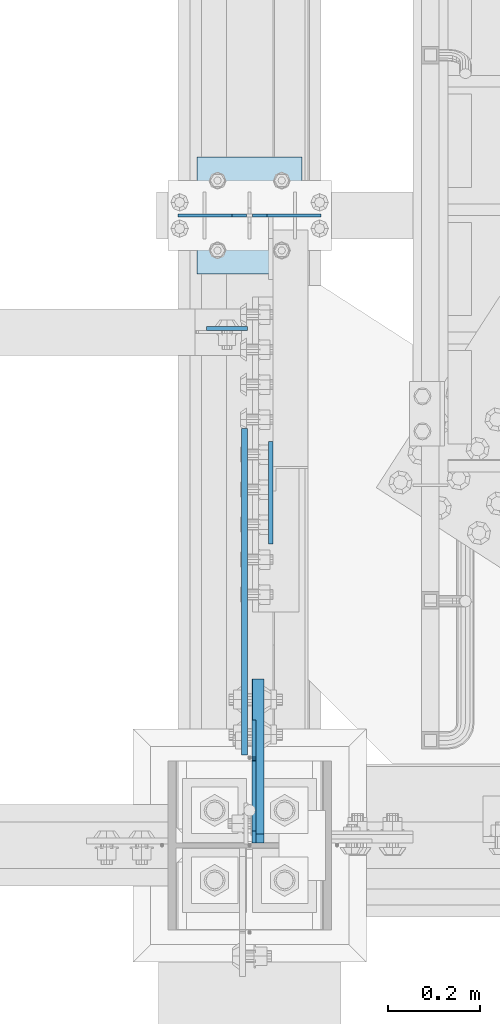
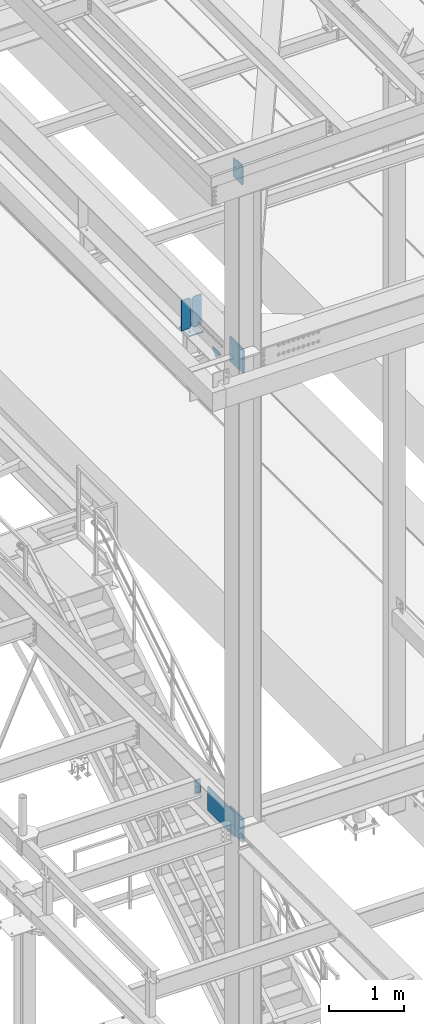
# One storey, part 3020 of 3843: 9 plates, 4 elements without a shape of their own.
"""IFC2X3 building model written with IfcOpenShell, lengths in millimetres."""

import ifcopenshell
import ifcopenshell.guid

model = None  # the IFC model being written
_history = None  # IfcOwnerHistory: only IFC2X3 demands one
_inside = {}  # id of a spatial element -> (the spatial element, [elements in it])
_under = {}  # id of a project, library or spatial element -> (it, [spatial elements below it])
_declared = {}  # id of a project -> (the project, [libraries it declares])
_typed = {}  # id of a type object -> (the type object, [elements of that type])
_made_of = {}  # id of a material, layer set ... -> (it, [elements and type objects made of it])


def new_model(schema):
    """Start an empty IFC model of exactly this schema.

    Asked for "IFC4X3", IfcOpenShell would pick the latest addendum, in which some entities
    have other attributes; the version numbers below select the first issue.
    IFC2X3 requires an IfcOwnerHistory on every rooted entity: one is made here for all.
    """
    global model, _history
    if schema == "IFC4X3":
        model = ifcopenshell.file(schema_version=(4, 3, 0, 0))
    else:
        model = ifcopenshell.file(schema=schema)
    _inside.clear()
    _under.clear()
    _declared.clear()
    _typed.clear()
    _made_of.clear()
    _history = None
    if model.schema == "IFC2X3":
        org = make("IfcOrganization", Name="unknown")
        user = make(
            "IfcPersonAndOrganization",
            ThePerson=make("IfcPerson", FamilyName="unknown"),
            TheOrganization=org,
        )
        app = make(
            "IfcApplication",
            ApplicationDeveloper=org,
            Version="unknown",
            ApplicationFullName="unknown",
            ApplicationIdentifier="unknown",
        )
        _history = make(
            "IfcOwnerHistory",
            OwningUser=user,
            OwningApplication=app,
            ChangeAction="ADDED",
            CreationDate=0,
        )
    return model


def make(cls, **values):
    """One entity of the class cls with the attributes given. An attribute that is None is left unset."""
    return model.create_entity(
        cls, **{name: value for name, value in values.items() if value is not None}
    )


def rooted(cls, **values):
    """An entity with a GlobalId (a new one), such as an element, a storey or a relation."""
    return make(cls, GlobalId=ifcopenshell.guid.new(), OwnerHistory=_history, **values)


def si_unit(unit_type, name, prefix=None):
    """IfcSIUnit, for example si_unit("LENGTHUNIT", "METRE", prefix="MILLI")."""
    return make("IfcSIUnit", UnitType=unit_type, Prefix=prefix, Name=name)


def assignment(units):
    """IfcUnitAssignment: the units of a project."""
    return None if units is None else make("IfcUnitAssignment", Units=units)


def point(xyz):
    """IfcCartesianPoint."""
    return None if xyz is None else make("IfcCartesianPoint", Coordinates=xyz)


def direction(xyz):
    """IfcDirection."""
    return None if xyz is None else make("IfcDirection", DirectionRatios=xyz)


def frame(location, z_axis=None, x_axis=None):
    """IfcAxis2Placement3D, a coordinate frame: its origin and axes. An axis left out is left unset."""
    return make(
        "IfcAxis2Placement3D",
        Location=point(location),
        Axis=direction(z_axis),
        RefDirection=direction(x_axis),
    )


def origin_with_axes():
    """The frame at (0, 0, 0) with the z axis (0, 0, 1) and the x axis (1, 0, 0) written out."""
    return frame((0.0, 0.0, 0.0), z_axis=(0.0, 0.0, 1.0), x_axis=(1.0, 0.0, 0.0))


def place(relative_to, where):
    """IfcLocalPlacement: puts the frame where relative to a parent placement (None: the world)."""
    return make(
        "IfcLocalPlacement", PlacementRelTo=relative_to, RelativePlacement=where
    )


def context(
    kind, dimensions, precision=None, world=None, true_north=None, identifier=None
):
    """IfcGeometricRepresentationContext, for example the 3D "Model" context."""
    return make(
        "IfcGeometricRepresentationContext",
        ContextIdentifier=identifier,
        ContextType=kind,
        CoordinateSpaceDimension=dimensions,
        Precision=precision,
        WorldCoordinateSystem=world,
        TrueNorth=true_north,
    )


def subcontext(parent, identifier, kind, view, scale=None):
    """IfcGeometricRepresentationSubContext, for example "Body" below "Model"."""
    return make(
        "IfcGeometricRepresentationSubContext",
        ContextIdentifier=identifier,
        ContextType=kind,
        ParentContext=parent,
        TargetScale=scale,
        TargetView=view,
    )


def project(units=None, contexts=None):
    """IfcProject with its units and contexts."""
    return rooted(
        "IfcProject",
        Name="project",
        RepresentationContexts=contexts,
        UnitsInContext=assignment(units),
    )


def spatial(cls, under=None, at=None, **own):
    """A site, building, storey or space (cls), placed at a placement, below another one or the project."""
    s = rooted(cls, ObjectPlacement=at, **own)
    if under is not None:
        _under.setdefault(under.id(), (under, []))[1].append(s)
    return s


def faces_of(points, faces, orient=None, outer=None):
    """IfcFace entities. A face is a list of loops; a loop is a list of indices into points, from 0.

    orient and outer hold one flag for each loop. By default every Orientation is true, the
    first loop of a face is its IfcFaceOuterBound and the others are IfcFaceBound.
    """
    made = []
    for i, loops in enumerate(faces):
        bounds = []
        for j, loop in enumerate(loops):
            is_outer = j == 0 if outer is None else outer[i][j]
            bounds.append(
                make(
                    "IfcFaceOuterBound" if is_outer else "IfcFaceBound",
                    Bound=make("IfcPolyLoop", Polygon=[points[k] for k in loop]),
                    Orientation=True if orient is None else orient[i][j],
                )
            )
        made.append(make("IfcFace", Bounds=bounds))
    return made


def faceted_brep(points, faces, orient=None, outer=None, voids=None):
    """IfcFacetedBrep: a solid bounded by flat faces; with voids (closed shells), ...WithVoids."""
    shared = [point(p) for p in points]
    hull = make("IfcClosedShell", CfsFaces=faces_of(shared, faces, orient, outer))
    if voids is None:
        return make("IfcFacetedBrep", Outer=hull)
    return make(
        "IfcFacetedBrepWithVoids",
        Outer=hull,
        Voids=[
            make(cls, CfsFaces=faces_of(shared, fs, o, b)) for cls, fs, o, b in voids
        ],
    )


def shape(context_of_items, identifier, shape_type, items):
    """IfcShapeRepresentation: the items that make up one representation, for example the "Body"."""
    return make(
        "IfcShapeRepresentation",
        ContextOfItems=context_of_items,
        RepresentationIdentifier=identifier,
        RepresentationType=shape_type,
        Items=items,
    )


def material(Name=None, Category=None):
    """IfcMaterial."""
    return make("IfcMaterial", Name=Name, Category=Category)


def made_of(thing, what):
    """Note that an element or type object is made of a material, layer set ...; save() writes the relation."""
    if what is not None:
        _made_of.setdefault(what.id(), (what, []))[1].append(thing)
    return thing


def type_object(cls, material=None, **own):
    """A type object (cls), such as IfcWallType, which elements share."""
    return made_of(rooted(cls, **own), material)


def element(
    cls,
    number,
    at=None,
    inside=None,
    cuts=None,
    type_object=None,
    material=None,
    context=None,
    identifier="Body",
    shape_type=None,
    held_by="IfcProductDefinitionShape",
    body=None,
    shapes=None,
    **own,
):
    """One element of the class cls, such as IfcWall. Its Tag is "e" and its number.

    at: its placement. inside: the storey or other place that contains it. cuts: it is an
    opening in that element (IfcRelVoidsElement). A single representation is given by context,
    identifier, shape_type and body (its items); several are given by shapes. held_by: the class
    of the entity that holds the representations. save() writes the other relations.
    """
    e = rooted(cls, Tag="e%d" % number, ObjectPlacement=at, **own)
    if body is not None:
        shapes = [shape(context, identifier, shape_type, body)]
    if shapes is not None:
        e.Representation = make(held_by, Representations=shapes)
    if inside is not None:
        _inside.setdefault(inside.id(), (inside, []))[1].append(e)
    if cuts is not None:
        rooted(
            "IfcRelVoidsElement", RelatingBuildingElement=cuts, RelatedOpeningElement=e
        )
    if type_object is not None:
        _typed.setdefault(type_object.id(), (type_object, []))[1].append(e)
    return made_of(e, material)


def aggregate(whole, parts):
    """IfcRelAggregates: a whole, such as a stair, and the parts it consists of."""
    return rooted("IfcRelAggregates", RelatingObject=whole, RelatedObjects=parts)


def save(model, path):
    """Write the relations noted so far, then the file.

    IfcRelAggregates (storeys below a building ...), IfcRelContainedInSpatialStructure (elements
    in a storey), IfcRelDefinesByType, IfcRelAssociatesMaterial and IfcRelDeclares: one each for
    every whole, place, type object, material and project.
    """
    for whole, parts in _under.values():
        aggregate(whole, parts)
    for where, things in _inside.values():
        rooted(
            "IfcRelContainedInSpatialStructure",
            RelatedElements=things,
            RelatingStructure=where,
        )
    for kind, things in _typed.values():
        rooted("IfcRelDefinesByType", RelatedObjects=things, RelatingType=kind)
    for what, things in _made_of.values():
        rooted("IfcRelAssociatesMaterial", RelatedObjects=things, RelatingMaterial=what)
    for by, libraries in _declared.values():
        rooted("IfcRelDeclares", RelatingContext=by, RelatedDefinitions=libraries)
    model.write(path)


model = new_model("IFC2X3")

# Units and contexts
model_context = context("Model", 3, precision=1e-05, world=origin_with_axes())
body_context = subcontext(model_context, "Body", "Model", "MODEL_VIEW")
ifc_project = project(units=[si_unit("LENGTHUNIT", "METRE", prefix="MILLI"), si_unit("AREAUNIT", "SQUARE_METRE"), si_unit("VOLUMEUNIT", "CUBIC_METRE"), si_unit("MASSUNIT", "GRAM", prefix="KILO"), si_unit("TIMEUNIT", "SECOND"), si_unit("PLANEANGLEUNIT", "RADIAN"), si_unit("SOLIDANGLEUNIT", "STERADIAN"), si_unit("THERMODYNAMICTEMPERATUREUNIT", "DEGREE_CELSIUS"), si_unit("LUMINOUSINTENSITYUNIT", "LUMEN")], contexts=[model_context])

# Site, building, storey
site_placement = place(None, origin_with_axes())
site = spatial("IfcSite", under=ifc_project, at=site_placement, CompositionType="ELEMENT")
building_placement = place(site_placement, origin_with_axes())
building = spatial("IfcBuilding", under=site, at=building_placement, Name="Undefined", CompositionType="ELEMENT")
storey_placement = place(building_placement, origin_with_axes())
storey = spatial("IfcBuildingStorey", under=building, at=storey_placement, Name="Undefined", CompositionType="ELEMENT", Elevation=0.0)

# Assembly, plate
assembly_1_placement = place(storey_placement, origin_with_axes())
assembly_1 = element("IfcElementAssembly", 1, at=assembly_1_placement, inside=storey, Name="COLUMN", AssemblyPlace="NOTDEFINED", PredefinedType="RIGID_FRAME")
ifc_material = material(Name="STEEL/A572-50")
plate_type_1 = type_object("IfcPlateType", PredefinedType="NOTDEFINED")
plate_1_placement = place(assembly_1_placement, frame((36595.0499999046, 25621.45625, 42411.65), z_axis=(0.0, 1.0, 0.0), x_axis=(0.0, 0.0, -1.0)))
plate_1 = element("IfcPlate", 2, at=plate_1_placement, type_object=plate_type_1, material=ifc_material, Name="PLATE", context=body_context, shape_type="Brep", body=[
    faceted_brep([(0.0, -12.6999999999971, 19.0499992370605), (0.0, -12.6999999999971, 356.393737792969), (0.0, 12.6999999999971, 356.393737792969), (0.0, 12.6999999999971, 19.0499992370605), (393.700012207031, -12.6999999999971, 356.393737792969), (393.700012207031, 12.6999999999971, 356.393737792969), (393.700012207031, -12.6999999999971, 19.0499992370605), (393.700012207031, 12.6999999999971, 19.0499992370605), (374.650012969971, -12.6999999999971, 0.0), (374.650012969971, 12.6999999999971, 0.0), (19.0500015258731, -12.6999999999971, -6.33008312433958e-10), (19.0500015258731, 12.6999999999971, 0.0)], [[[0, 1, 2, 3]], [[1, 4, 5, 2]], [[4, 6, 7, 5]], [[6, 8, 9, 7]], [[8, 10, 11, 9]], [[10, 0, 3, 11]], [[5, 7, 9, 11, 3, 2]], [[10, 8, 6, 4, 1, 0]]]),
])

assembly_2_placement = place(storey_placement, origin_with_axes())
assembly_2 = element("IfcElementAssembly", 3, at=assembly_2_placement, inside=storey, Name="BEAM", AssemblyPlace="NOTDEFINED", PredefinedType="RIGID_FRAME")
plate_type_2 = type_object("IfcPlateType", PredefinedType="NOTDEFINED")
plate_2_placement = place(assembly_2_placement, frame((36571.2375, 26741.4375, 34772.6), z_axis=(-1.0, 0.0, 0.0), x_axis=(0.0, 0.0, -1.0)))
plate_2 = element("IfcPlate", 4, at=plate_2_placement, type_object=plate_type_2, material=ifc_material, Name="PLATE", context=body_context, shape_type="Brep", body=[
    faceted_brep([(0.0, -4.76249999999709, 0.0), (0.0, -4.76249999999709, 88.9000015258789), (0.0, 4.76249999999709, 88.9000015258789), (0.0, 4.76249999999709, 0.0), (228.600006102781, -4.7625000004191, 88.9000015257589), (228.600006102781, 4.76249999954598, 88.9000015257443), (228.600006103079, -4.7625000004482, 7.27595761418343e-12), (228.600006103079, 4.76249999954598, -7.27595761418343e-12)], [[[0, 1, 2, 3]], [[1, 4, 5, 2]], [[4, 6, 7, 5]], [[6, 0, 3, 7]], [[5, 7, 3, 2]], [[6, 4, 1, 0]]]),
])

# Plate
plate_type_3 = type_object("IfcPlateType", PredefinedType="NOTDEFINED")
plate_3_placement = place(assembly_1_placement, frame((36593.4625, 25621.45625, 34404.3), z_axis=(0.0, 0.707106781186548, 0.707106781186548), x_axis=(5.70000238222118e-08, 0.707106781186546, -0.707106781186546)))
plate_3 = element("IfcPlate", 5, at=plate_3_placement, type_object=plate_type_3, material=ifc_material, Name="PLATE", context=body_context, shape_type="Brep", body=[
    faceted_brep([(0.0, -12.6999999999971, 0.0), (-251.44717138874, -12.6999999999971, 251.447171388725), (-251.44717138874, 12.6999999999971, 251.447171388725), (0.0, 12.6999999999971, 0.0), (-251.447171388732, -12.6999999999971, 278.387939751803), (-251.447171388732, 12.6999999999971, 278.387939751803), (-12.9091181739714, -12.6999999999971, 516.92599296655), (-12.9091181739714, 12.6999999999971, 516.92599296655), (265.478821577828, -12.6999999999971, 238.538053214754), (265.478821577828, 12.6999999999971, 238.538053214754), (26.9407683630998, -12.7000000000007, 3.63797880709171e-12), (26.9407683630998, 12.7000000000007, 3.63797880709171e-12)], [[[0, 1, 2, 3]], [[1, 4, 5, 2]], [[4, 6, 7, 5]], [[6, 8, 9, 7]], [[8, 10, 11, 9]], [[10, 0, 3, 11]], [[5, 7, 9, 11, 3, 2]], [[10, 8, 6, 4, 1, 0]]]),
])

# Assembly, plates
assembly_3_placement = place(storey_placement, origin_with_axes())
assembly_3 = element("IfcElementAssembly", 6, at=assembly_3_placement, inside=storey, Name="BEAM", AssemblyPlace="NOTDEFINED", PredefinedType="RIGID_FRAME")
plate_type_4 = type_object("IfcPlateType", PredefinedType="NOTDEFINED")
plate_4_placement = place(assembly_3_placement, frame((36731.575, 26987.5, 42446.575), z_axis=(0.0, 0.0, -1.0), x_axis=(-1.0, 0.0, 0.0)))
plate_4 = element("IfcPlate", 7, at=plate_4_placement, type_object=plate_type_4, material=ifc_material, Name="PLATE", context=body_context, shape_type="Brep", body=[
    faceted_brep([(0.0, -3.17499999999927, 0.0), (0.0, -3.17500000000291, 498.475000000006), (0.0, 3.17500000000291, 498.475000000006), (0.0, 3.17499999999927, 0.0), (117.475000000006, -3.17500000000291, 498.475000000006), (117.475000000006, 3.17500000000291, 498.475000000006), (149.225000000006, -3.17500000000291, 466.725000000006), (149.225000000006, 3.17500000000291, 466.725000000006), (149.225000000006, -3.17500000000291, 31.75), (149.225000000006, 3.17500000000291, 31.75), (117.475000000006, -3.17500000000291, 0.0), (117.475000000006, 3.17500000000291, 0.0)], [[[0, 1, 2, 3]], [[1, 4, 5, 2]], [[4, 6, 7, 5]], [[6, 8, 9, 7]], [[8, 10, 11, 9]], [[10, 0, 3, 11]], [[5, 7, 9, 11, 3, 2]], [[10, 8, 6, 4, 1, 0]]]),
])
plate_5_placement = place(assembly_3_placement, frame((36420.425, 26987.5, 42446.575), z_axis=(0.0, 0.0, -1.0), x_axis=(1.0, 0.0, 0.0)))
plate_5 = element("IfcPlate", 8, at=plate_5_placement, type_object=plate_type_4, material=ifc_material, Name="PLATE", context=body_context, shape_type="Brep", body=[
    faceted_brep([(0.0, -3.17499999999927, 0.0), (0.0, -3.17500000000291, 498.475000000006), (0.0, 3.17500000000291, 498.475000000006), (0.0, 3.17499999999927, 0.0), (117.475000000006, -3.17500000000291, 498.475000000006), (117.475000000006, 3.17500000000291, 498.475000000006), (149.225000000006, -3.17500000000291, 466.725000000006), (149.225000000006, 3.17500000000291, 466.725000000006), (149.225000000006, -3.17500000000291, 31.75), (149.225000000006, 3.17500000000291, 31.75), (117.475000000006, -3.17500000000291, 0.0), (117.475000000006, 3.17500000000291, 0.0)], [[[0, 1, 2, 3]], [[1, 4, 5, 2]], [[4, 6, 7, 5]], [[6, 8, 9, 7]], [[8, 10, 11, 9]], [[10, 0, 3, 11]], [[5, 7, 9, 11, 3, 2]], [[10, 8, 6, 4, 1, 0]]]),
])

# Assembly, plate
assembly_4_placement = place(storey_placement, origin_with_axes())
assembly_4 = element("IfcElementAssembly", 9, at=assembly_4_placement, inside=storey, Name="POST", AssemblyPlace="NOTDEFINED", PredefinedType="RIGID_FRAME")
plate_type_5 = type_object("IfcPlateType", PredefinedType="NOTDEFINED")
plate_6_placement = place(assembly_4_placement, frame((36461.7000005181, 27114.5, 41916.35), z_axis=(0.0, -1.0, 0.0), x_axis=(1.0, 0.0, 0.0)))
plate_6 = element("IfcPlate", 10, at=plate_6_placement, type_object=plate_type_5, material=ifc_material, Name="PLATE", context=body_context, shape_type="Brep", body=[
    faceted_brep([(0.0, -9.52500000000146, 0.0), (0.0, -9.52500000000146, 254.0), (0.0, 9.52500000000146, 254.0), (0.0, 9.52500000000146, 0.0), (228.599999999999, -9.52500000000146, 254.0), (228.599999999999, 9.52500000000146, 254.0), (228.599999999999, -9.52500000000146, 0.0), (228.599999999999, 9.52500000000146, 0.0)], [[[0, 1, 2, 3]], [[1, 4, 5, 2]], [[4, 6, 7, 5]], [[6, 0, 3, 7]], [[5, 7, 3, 2]], [[6, 4, 1, 0]]]),
])
aggregate(assembly_4, [plate_6])

# Plate
plate_type_6 = type_object("IfcPlateType", PredefinedType="NOTDEFINED")
plate_7_placement = place(assembly_3_placement, frame((36622.0375, 26272.1289773786, 41925.875), z_axis=(0.0, 0.707106781186548, 0.707106781186548), x_axis=(5.70000238222118e-08, 0.707106781186546, -0.707106781186546)))
plate_7 = element("IfcPlate", 11, at=plate_7_placement, type_object=plate_type_6, material=ifc_material, Name="PLATE", context=body_context, shape_type="Brep", body=[
    faceted_brep([(0.0, -4.76249999999709, 0.0), (157.726597423803, -4.76249999999709, 157.726601438866), (157.726597423803, 4.76249999999709, 157.726601438866), (0.0, 4.76249999999709, 0.0), (188.387110059113, -4.76249999999709, 127.066089584019), (188.387110059113, 4.76249999999709, 127.066089584019), (188.387111679331, -4.76249999999709, 1.09139364212751e-10), (188.387111679331, 4.76249999999709, 1.09139364212751e-10)], [[[0, 1, 2, 3]], [[1, 4, 5, 2]], [[4, 6, 7, 5]], [[6, 0, 3, 7]], [[5, 7, 3, 2]], [[6, 4, 1, 0]]]),
])

aggregate(assembly_3, [plate_4, plate_5, plate_7])

plate_type_7 = type_object("IfcPlateType", PredefinedType="NOTDEFINED")
plate_8_placement = place(assembly_2_placement, frame((36564.8875, 25812.75, 34385.249987793), z_axis=(0.0, 0.0, 1.0), x_axis=(0.0, 1.0, 0.0)))
plate_8 = element("IfcPlate", 12, at=plate_8_placement, type_object=plate_type_7, material=ifc_material, Name="PLATE", context=body_context, shape_type="Brep", body=[
    faceted_brep([(0.0, -6.3499999046162, 0.0), (0.0, -6.34999999999854, 393.700012207031), (0.0, 6.34999999999854, 393.700012207031), (7.27595761418343e-12, 6.3499999046162, 0.0), (711.199999999968, -6.35000000000582, 393.700012207031), (711.200000000012, 6.34999999999854, 393.700000000004), (711.199999999968, -6.35000000000582, 0.0), (711.199999999997, 6.34999999999854, 0.0)], [[[0, 1, 2, 3]], [[1, 4, 5, 2]], [[4, 6, 7, 5]], [[6, 0, 3, 7]], [[7, 3, 2, 5]], [[6, 4, 1, 0]]]),
])

aggregate(assembly_2, [plate_2, plate_8])

plate_type_8 = type_object("IfcPlateType", PredefinedType="NOTDEFINED")
plate_9_placement = place(assembly_1_placement, frame((36585.5254999161, 25621.45625, 45100.8750026613), z_axis=(0.0, 0.707106781186548, 0.707106781186548), x_axis=(5.70000238222118e-08, 0.707106781186546, -0.707106781186546)))
plate_9 = element("IfcPlate", 13, at=plate_9_placement, type_object=plate_type_8, material=ifc_material, Name="PLATE", context=body_context, shape_type="Brep", body=[
    faceted_brep([(0.0, -4.76249999999709, 0.0), (-191.952976016832, -4.76249999999709, 191.952973157036), (-191.952976016832, 4.76249999999709, 191.952973157036), (0.0, 4.76249999999709, 0.0), (-191.952976016781, -4.76249999999709, 227.873997373681), (-191.952976016781, 4.76249999999709, 227.873997373681), (-83.628636084215, -4.76249999999709, 336.198335692912), (-83.628636084215, 4.76249999999709, 336.198335692912), (-80.2610389475558, -4.76250000000073, 332.830742350503), (-80.2610389475558, 4.76250000000073, 332.830742350503), (-76.1408624794058, -4.76250000000073, 330.077728450029), (-76.1408624794058, 4.76250000000073, 330.077728450029), (-71.2807829613703, -4.76250000000073, 329.110998527467), (-71.2807829613703, 4.76250000000073, 329.110998527467), (-66.4207034433384, -4.76250000000073, 330.077728450065), (-66.4207034433384, 4.76250000000073, 330.077728450065), (-62.300526975203, -4.76250000000073, 332.830742350532), (-62.300526975203, 4.76250000000073, 332.830742350532), (-8.41899011431451, -4.76250000000073, 386.712279211657), (-8.41899011431451, 4.76250000000073, 386.712279211657), (207.107160643502, -4.76249999999709, 171.186135214331), (207.107160643502, 4.76249999999709, 171.186135214331), (35.9210247517349, -4.76249999999709, 1.30967237055302e-10), (35.9210247517349, 4.76249999999709, 1.30967237055302e-10)], [[[0, 1, 2, 3]], [[1, 4, 5, 2]], [[4, 6, 7, 5]], [[6, 8, 9, 7]], [[8, 10, 11, 9]], [[10, 12, 13, 11]], [[12, 14, 15, 13]], [[14, 16, 17, 15]], [[16, 18, 19, 17]], [[18, 20, 21, 19]], [[20, 22, 23, 21]], [[22, 0, 3, 23]], [[5, 7, 9, 11, 13, 15, 17, 19, 21, 23, 3, 2]], [[22, 20, 18, 16, 14, 12, 10, 8, 6, 4, 1, 0]]]),
])

aggregate(assembly_1, [plate_1, plate_9, plate_3])

save(model, "model.ifc")
